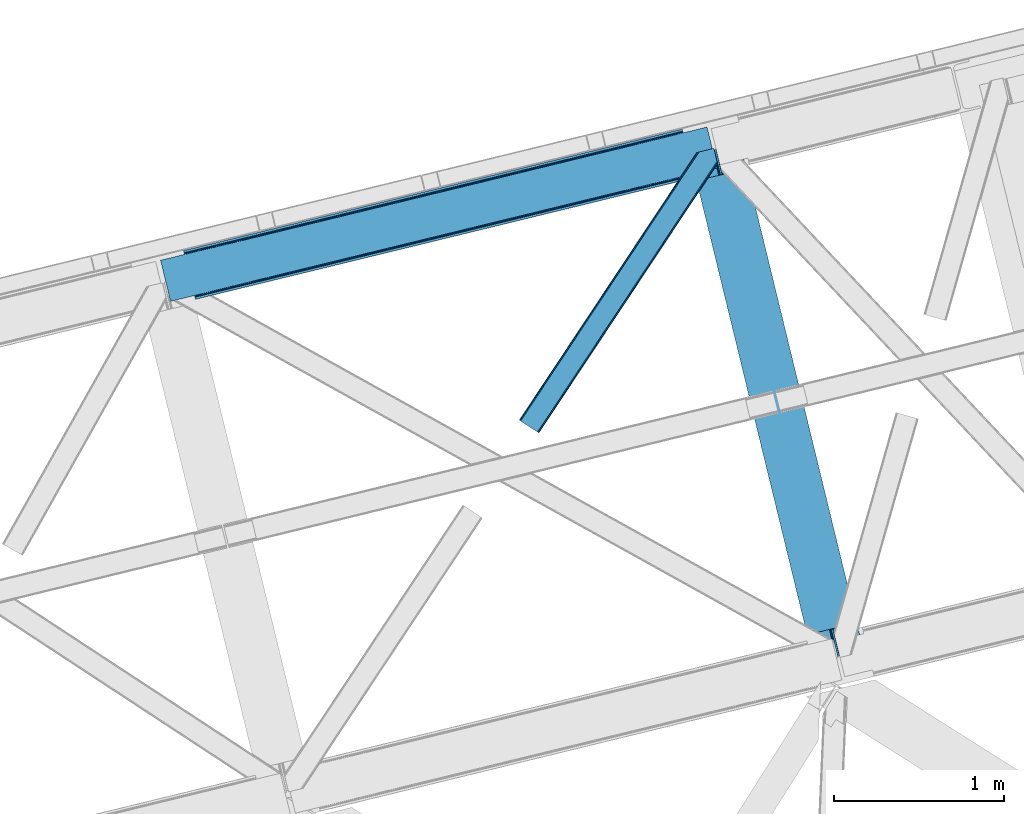
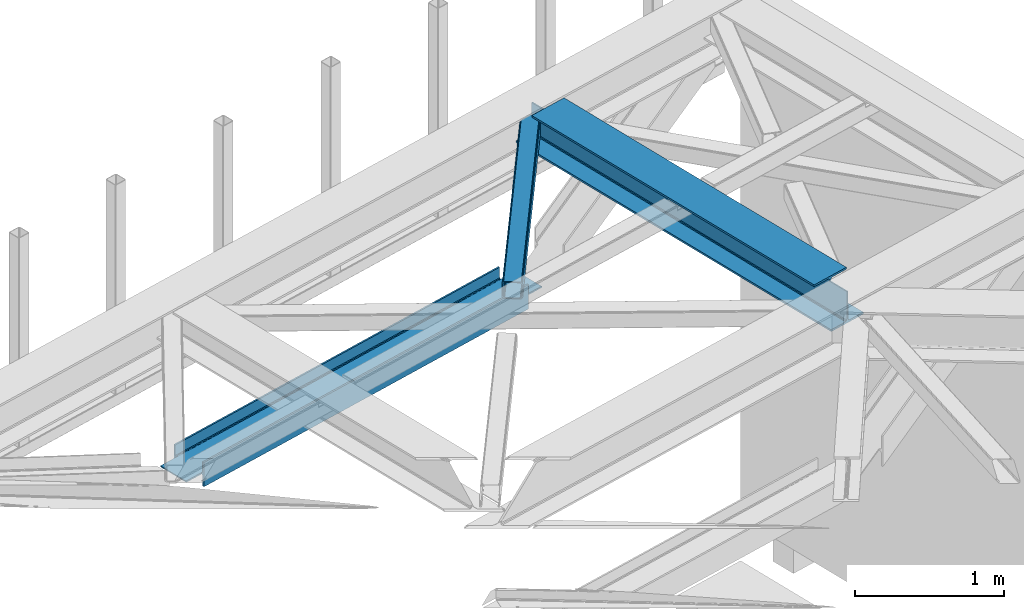
# One storey, part 60 of 67: 2 members, 1 beam.
"""IFC4 building model written with IfcOpenShell, lengths in millimetres."""

from ifc_helpers import new_model, entity, si_unit, converted_unit, derived_unit, direction, frame, origin, place, context, subcontext, project, spatial, triangles, polygons, material, type_object, element, save


model = new_model("IFC4")

# Units and contexts
model_context = context("Model", 3, precision=0.01, world=origin(), true_north=direction((6.12303176911189e-17, 1.0)))
plan_context = context("Plan", 3, precision=0.01, world=origin(), true_north=direction((6.12303176911189e-17, 1.0)))
body_context = subcontext(model_context, "Body", "Model", "MODEL_VIEW")
ifc_project = project(units=[si_unit("LENGTHUNIT", "METRE", prefix="MILLI"), si_unit("AREAUNIT", "SQUARE_METRE"), si_unit("VOLUMEUNIT", "CUBIC_METRE"), converted_unit("PLANEANGLEUNIT", "DEGREE", entity("IfcRatioMeasure", 0.0174532925199433), si_unit("PLANEANGLEUNIT", "RADIAN"), dimensions=[0, 0, 0, 0, 0, 0, 0]), si_unit("MASSUNIT", "GRAM", prefix="KILO"), derived_unit("MASSDENSITYUNIT", [(si_unit("MASSUNIT", "GRAM", prefix="KILO"), 1), (si_unit("LENGTHUNIT", "METRE"), -3)]), derived_unit("MOMENTOFINERTIAUNIT", [(si_unit("LENGTHUNIT", "METRE"), 4)]), si_unit("TIMEUNIT", "SECOND"), si_unit("FREQUENCYUNIT", "HERTZ"), si_unit("THERMODYNAMICTEMPERATUREUNIT", "DEGREE_CELSIUS"), derived_unit("THERMALTRANSMITTANCEUNIT", [(si_unit("MASSUNIT", "GRAM", prefix="KILO"), 1), (si_unit("THERMODYNAMICTEMPERATUREUNIT", "KELVIN"), -1), (si_unit("TIMEUNIT", "SECOND"), -3)]), derived_unit("VOLUMETRICFLOWRATEUNIT", [(si_unit("LENGTHUNIT", "METRE"), 3), (si_unit("TIMEUNIT", "SECOND"), -1)]), derived_unit("MASSFLOWRATEUNIT", [(si_unit("MASSUNIT", "GRAM", prefix="KILO"), 1), (si_unit("TIMEUNIT", "SECOND"), -1)]), derived_unit("ROTATIONALFREQUENCYUNIT", [(si_unit("TIMEUNIT", "SECOND"), -1)]), si_unit("ELECTRICCURRENTUNIT", "AMPERE"), si_unit("ELECTRICVOLTAGEUNIT", "VOLT"), si_unit("POWERUNIT", "WATT"), si_unit("FORCEUNIT", "NEWTON", prefix="KILO"), si_unit("ILLUMINANCEUNIT", "LUX"), si_unit("LUMINOUSFLUXUNIT", "LUMEN"), si_unit("LUMINOUSINTENSITYUNIT", "CANDELA"), derived_unit("USERDEFINED", [(si_unit("MASSUNIT", "GRAM", prefix="KILO"), -1), (si_unit("LENGTHUNIT", "METRE"), -2), (si_unit("TIMEUNIT", "SECOND"), 3), (si_unit("LUMINOUSFLUXUNIT", "LUMEN"), 1)]), derived_unit("LINEARVELOCITYUNIT", [(si_unit("LENGTHUNIT", "METRE"), 1), (si_unit("TIMEUNIT", "SECOND"), -1)]), si_unit("PRESSUREUNIT", "PASCAL"), derived_unit("USERDEFINED", [(si_unit("LENGTHUNIT", "METRE"), -2), (si_unit("MASSUNIT", "GRAM", prefix="KILO"), 1), (si_unit("TIMEUNIT", "SECOND"), -2)]), derived_unit("LINEARFORCEUNIT", [(si_unit("MASSUNIT", "GRAM", prefix="KILO"), 1), (si_unit("LENGTHUNIT", "METRE"), 1), (si_unit("TIMEUNIT", "SECOND"), -2), (si_unit("LENGTHUNIT", "METRE"), -1)]), derived_unit("PLANARFORCEUNIT", [(si_unit("MASSUNIT", "GRAM", prefix="KILO"), 1), (si_unit("LENGTHUNIT", "METRE"), 1), (si_unit("TIMEUNIT", "SECOND"), -2), (si_unit("LENGTHUNIT", "METRE"), -2)])], contexts=[model_context, plan_context])

# Site, building, storey
site_placement = place(None, origin())
site = spatial("IfcSite", under=ifc_project, at=site_placement, CompositionType="ELEMENT")
building_placement = place(site_placement, origin())
building = spatial("IfcBuilding", under=site, at=building_placement, CompositionType="ELEMENT")
storey_placement = place(building_placement, frame((0.0, 0.0, 19800.0)))
storey = spatial("IfcBuildingStorey", under=building, at=storey_placement, CompositionType="ELEMENT", Elevation=19800.0)

# Beam
ifc_material = material(Name="Metal painted (White)")
beam_type = type_object("IfcBeamType", PredefinedType="BEAM")
beam_placement = place(storey_placement, frame((-3043.27889836329, 17053.0977839193, 3807.02022389142)))
element("IfcBeam", 1, at=beam_placement, inside=storey, type_object=beam_type, material=ifc_material, ObjectType="Steel Beam", PredefinedType="BEAM", context=body_context, shape_type="Tessellation", body=[
    polygons([(1018.16648378329, 71.0478278971, 15.5000000000008), (1018.16648378329, 71.0478278971, 0.0), (291.465617442441, 3052.25531830421, 0.0), (291.46561744244, 3052.25531830421, 15.5000000000008), (894.779372399327, 40.970914087327, 15.5000000000008), (168.078506058477, 3022.17840449444, 15.5000000000008), (888.087028625373, 39.3395844888221, 16.8701684147984), (161.386162284522, 3020.54707489593, 16.8701684147984), (882.413533524753, 37.9566100336519, 20.7720779386391), (155.712667183902, 3019.16410044076, 20.7720779386391), (878.622625296174, 37.032536045914, 26.6116982174294), (151.921758955324, 3018.24002645303, 26.6116982174294), (877.29143535278, 36.7080444135029, 33.500000000001), (150.59056901193, 3017.91553482061, 33.500000000001), (140.875048430515, 3015.54727389071, 33.500000000001), (140.875048430516, 3015.54727389071, 259.000000000002), (150.590569011928, 3017.91553482061, 259.000000000002), (5.41433564649196e-13, 2981.20749040711, 0.0), (1.08286712929839e-12, 2981.20749040711, 15.4999999999965), (123.387111383957, 3011.28440421688, 15.5000000000008), (130.079455157929, 3012.91573381539, 16.8701684147984), (135.752950258545, 3014.29870827056, 20.7720779386391), (139.543858487118, 3015.22278225829, 26.6116982174294), (877.291435352778, 36.7080444135029, 259.000000000002), (867.575914771367, 34.3397834835992, 259.000000000002), (867.575914771365, 34.3397834835992, 33.500000000001), (866.244724827968, 34.0152918511816, 26.6116982174294), (862.453816599396, 33.0912178634502, 20.7720779386391), (856.78032149878, 31.70824340828, 16.8701684147984), (850.087977724808, 30.0769138097708, 15.5000000000008), (726.700866340852, -2.16573425859679e-12, 15.4999999999965), (726.700866340851, -2.16573425859679e-12, 0.0), (838.124523615906, 197.385937999179, 259.069791973884), (186.469722099963, 2870.72539801218, 259.000000000002), (186.693115201815, 2869.8089536072, 259.617303331124), (186.705504045442, 2869.75812937344, 266.500003008253), (837.97934480814, 197.9814160017, 266.500002998871), (837.979694928892, 197.979979696968, 260.000004007589), (828.499586345875, 194.645865944432, 259.006343171919), (828.276216326112, 195.562317481909, 259.617303331124), (828.263827482483, 195.613141715687, 266.500003008253), (176.989986719785, 2867.38985508742, 266.500002998871), (176.989636599033, 2867.39129139215, 260.000004007589), (176.844830940693, 2867.98534020594, 259.07612046749), (176.754201518551, 2868.35713708228, 259.000000000002), (839.310832678069, 198.30468544639, 273.388305639783), (843.101109266761, 199.231350618303, 279.227924098781), (848.7741802143, 200.616065081979, 283.129832400619), (855.466371895431, 202.248018612794, 284.500000377228), (978.853400583269, 232.325271667903, 284.500000138971), (978.851730776618, 232.332121736637, 299.999995328161), (687.386308679348, 161.283492472594, 299.999995890962), (687.387978485999, 161.276642403861, 284.500000701776), (810.775007173834, 191.35389545897, 284.500000463519), (817.467494069994, 192.984637925553, 283.129832461069), (823.141405718745, 194.365903570076, 279.227924137322), (826.932940505739, 195.28740721937, 273.388305663684), (175.658498849857, 2867.06658564273, 273.388305639783), (171.868222261161, 2866.13992047082, 279.227924098781), (166.195151313635, 2864.75520600714, 283.129832400619), (159.502959632485, 2863.12325247633, 284.500000377228), (36.115930944656, 2833.04599942122, 284.500000138971), (36.117600751305, 2833.03914935249, 299.999995328161), (327.583022848576, 2904.08777861653, 299.999995890962), (327.581353041926, 2904.09462868526, 284.500000701776), (204.194324354083, 2874.01737563015, 284.500000463519), (197.501837457941, 2872.38663316357, 283.129832461069), (191.827925809177, 2871.00536751904, 279.227924137322), (188.036391022187, 2870.08386386975, 273.388305663684)], [[[1, 2, 3, 4]], [[5, 1, 4, 6]], [[7, 5, 6, 8]], [[9, 7, 8, 10]], [[11, 9, 10, 12]], [[13, 11, 12, 14]], [[15, 16, 17, 14, 12, 10, 8, 6, 4, 3, 18, 19, 20, 21, 22, 23]], [[13, 24, 25, 26, 27, 28, 29, 30, 31, 32, 2, 1, 5, 7, 9, 11]], [[2, 32, 18, 3]], [[32, 31, 19, 18]], [[31, 30, 20, 19]], [[27, 26, 15, 23]], [[28, 27, 23, 22]], [[29, 28, 22, 21]], [[30, 29, 21, 20]], [[33, 24, 13, 14, 17, 34, 35, 36, 37, 38]], [[25, 39, 40, 41, 42, 43, 44, 16, 15, 26]], [[39, 25, 24, 33]], [[45, 34, 17, 16]], [[41, 40, 38, 37, 46, 47, 48, 49, 50, 51, 52, 53, 54, 55, 56, 57]], [[42, 58, 59, 60, 61, 62, 63, 64, 65, 66, 67, 68, 69, 36, 35, 43]], [[46, 37, 36, 69]], [[47, 46, 69, 68]], [[48, 47, 68, 67]], [[49, 48, 67, 66]], [[50, 49, 66, 65]], [[51, 50, 65, 64]], [[52, 51, 64, 63]], [[53, 52, 63, 62]], [[54, 53, 62, 61]], [[55, 54, 61, 60]], [[56, 55, 60, 59]], [[57, 56, 59, 58]], [[41, 57, 58, 42]]], closed=False),
])

# Members
member_type_1 = type_object("IfcMemberType", PredefinedType="BRACE")
member_1_placement = place(storey_placement, frame((-4050.77483825684, 18401.5802764893, 3823.02086791992)))
element("IfcMember", 2, at=member_1_placement, inside=storey, type_object=member_type_1, ObjectType="Steel Horizontal Brace", PredefinedType="BRACE", context=body_context, shape_type="Tessellation", body=[
    triangles([(1012.13822021484, 1571.4587310791, 0.0), (1045.99690933228, 1432.55790710449, 0.0), (14.5796333312987, 67.7191223144546, 0.0), (102.080397033692, 9.67499084472729, 0.0), (1.10807189941397, 76.6569488525383, 10.8016662597656), (0.0, 77.3929504394546, 17.4989318847656), (1043.79529953003, 1650.83760681152, 17.4989318847656), (1007.73296585083, 1592.73185119629, 9.25757446288844), (4.27125091552716, 74.5605651855476, 5.12526855468604), (1007.87191085815, 1593.1829864502, 9.49942016601563), (1007.5829750061, 1592.24815979004, 8.99945068359375), (1007.43734436035, 1591.76446838379, 8.74132690429542), (1007.29839935303, 1591.31333312989, 8.49948120117188), (1008.14776611328, 1587.8298248291, 5.12526855468604), (1046.0907989502, 1651.39571228027, 10.8691040039048), (1046.56518859863, 1651.51198425293, 9.49942016601563), (1009.97875900269, 1580.31865539551, 1.33247680663771), (9.00003204345694, 71.4212219238289, 1.33247680663771), (1043.79529953003, 1650.83760681152, 122.499499511716), (0.0, 77.3929504394546, 122.499499511716), (1045.70215988159, 1651.30269470215, 129.196765136716), (1.10807189941397, 76.6569488525383, 129.196765136716), (1051.1335144043, 1652.62586975098, 134.873162841795), (4.27125091552716, 74.5605651855476, 134.873162841795), (1059.25772781372, 1654.60481872559, 138.668280029295), (9.00003204345694, 71.4212219238289, 138.668280029295), (1068.84609603882, 1656.94421081543, 139.998431396481), (14.5796333312987, 67.7191223144546, 139.998431396481), (1012.24141159058, 1575.25849914551, 9.49942016601563), (1011.99578704834, 1574.65621032715, 9.42268066406177), (1012.03008728027, 1573.63069152832, 9.11572265625), (1012.0707824707, 1572.60052185059, 8.80643920898365), (1012.10973358154, 1571.57732849121, 8.49948120117188), (1065.96342315674, 1656.23960266114, 9.49942016601563), (14.8357223510743, 67.5516906738303, 8.33204956054396), (20.4150329589843, 63.8495910644524, 6.99957275390625), (1014.39534988403, 1562.19883117676, 6.99957275390625), (10.1022903442381, 70.6898712158218, 12.1248413085923), (1061.15121688843, 1655.06758117676, 12.1248413085923), (1012.24228363037, 1571.03317565918, 8.41343994140334), (1055.7242225647, 1653.74440612793, 17.8035644531228), (1053.81300201416, 1653.27931823731, 24.4985046386719), (6.94376220703134, 72.7874176025398, 17.8035644531228), (5.83074874877912, 73.5234191894524, 24.4985046386719), (1043.73948898315, 1441.81780700684, 6.99957275390625), (96.244997406006, 13.5445220947258, 6.99957275390625), (1045.89284591675, 1432.98578796387, 8.41343994140334), (1046.02539596558, 1432.44163513184, 8.49948120117188), (1050.83643951416, 1412.70330505371, 8.49948120117188), (1049.98707275391, 1416.18913879395, 5.12526855468604), (1048.15637054443, 1423.69798278809, 1.33247680663771), (1053.81300201416, 1653.27931823731, 115.49992675781), (5.83074874877912, 73.5234191894524, 115.49992675781), (1069.28008117676, 1657.04885559082, 131.666381835938), (1078.86844940186, 1659.38592224121, 132.998858642575), (20.4150329589843, 63.8495910644524, 132.998858642575), (14.8357223510743, 67.5516906738303, 131.666381835938), (1061.15121688843, 1655.06758117676, 127.873590087889), (10.1022903442381, 70.6898712158218, 127.873590087889), (1055.7242225647, 1653.74440612793, 122.19719238281), (6.94376220703134, 72.7874176025398, 122.19719238281), (1145.26875686646, 1675.57098083496, 139.998431396481), (1145.26875686646, 1675.57098083496, 132.998858642575), (1161.91250839233, 1607.29375305176, 139.998431396481), (102.080397033692, 9.67499084472729, 139.998431396481), (1159.65537872314, 1616.5536529541, 132.998858642575), (96.244997406006, 13.5445220947258, 132.998858642575), (1164.07226028442, 1598.43382873535, 138.668280029295), (107.659998321533, 5.97289123535302, 138.668280029295), (1165.9029624939, 1590.92265930176, 134.873162841795), (112.388779449463, 2.83354797363427, 134.873162841795), (1167.12614364624, 1585.90436096191, 129.196765136716), (115.551958465576, 0.737164306639897, 129.196765136716), (1167.55576858521, 1584.14167785645, 122.499499511716), (116.660321044922, 0.0, 122.499499511716), (1167.55576858521, 1584.14167785645, 17.4989318847656), (116.660321044922, 0.0, 17.4989318847656), (106.557740020752, 6.7042419433601, 127.873590087889), (109.716268157959, 4.60553283691479, 122.19719238281), (110.829281616211, 3.87069396972583, 115.49992675781), (101.824308013916, 9.84125976562427, 131.666381835938), (115.551958465576, 0.737164306639897, 10.8016662597656), (106.557740020752, 6.7042419433601, 12.1248413085923), (112.388779449463, 2.83354797363427, 5.12526855468604), (110.829281616211, 3.87069396972583, 24.4985046386719), (109.716268157959, 4.60553283691479, 17.8035644531228), (107.659998321533, 5.97289123535302, 1.33247680663771), (101.824308013916, 9.84125976562427, 8.33204956054396), (1165.29834823608, 1593.40157775879, 115.49992675781), (1165.29834823608, 1593.40157775879, 24.4985046386719), (1164.86901397705, 1595.16426086426, 122.19719238281), (1163.64554214478, 1600.1825592041, 127.873590087889), (1161.8148399353, 1607.6937286377, 131.666381835938), (1164.7812286377, 1595.52470397949, 17.868676757811), (1167.54646682739, 1584.18121032715, 16.4989929199219), (1164.67425842285, 1595.96188659668, 16.4989929199219), (1050.96404800415, 1412.49401550293, 8.8831787109375), (1051.5055847168, 1412.90561828614, 9.29943237304542), (1051.768359375, 1413.10328063965, 9.49942016601563), (1162.81652297974, 1579.82333679199, 10.8714294433594), (1161.66310501099, 1578.76061096192, 9.49942016601563), (1160.35097579956, 1595.22007141114, 12.1248413085923), (1046.70355224609, 1430.89521789551, 9.20641479492042), (1046.36229400635, 1431.66726379394, 8.85294799804615), (1047.39885864258, 1431.02776794434, 9.49942016601563), (1157.29360427856, 1596.68742370605, 9.49942016601563)], [[1, 2, 3], [4, 3, 2], [5, 6, 7], [8, 9, 10], [9, 8, 11], [12, 9, 11], [9, 12, 13], [13, 14, 9], [5, 15, 10], [10, 9, 5], [15, 16, 10], [17, 1, 18], [3, 18, 1], [14, 17, 9], [18, 9, 17], [7, 15, 5], [19, 7, 6], [6, 20, 19], [21, 19, 22], [20, 22, 19], [23, 21, 24], [22, 24, 21], [25, 23, 26], [24, 26, 23], [27, 25, 28], [26, 28, 25], [8, 10, 29], [11, 8, 30], [12, 11, 31], [13, 12, 32], [32, 33, 13], [31, 32, 12], [30, 31, 11], [29, 30, 8], [16, 34, 29], [29, 10, 16], [35, 36, 37], [38, 30, 29], [29, 39, 38], [29, 34, 39], [38, 35, 40], [40, 33, 38], [31, 38, 32], [31, 30, 38], [38, 33, 32], [37, 40, 35], [41, 42, 43], [44, 43, 42], [39, 41, 38], [43, 38, 41], [45, 37, 36], [36, 46, 45], [1, 37, 45], [13, 33, 14], [33, 40, 1], [37, 1, 40], [33, 17, 14], [33, 1, 17], [2, 1, 45], [2, 45, 47], [48, 2, 47], [49, 50, 48], [48, 51, 2], [48, 50, 51], [42, 52, 44], [53, 44, 52], [54, 55, 56], [56, 57, 54], [58, 54, 57], [57, 59, 58], [60, 58, 59], [59, 61, 60], [52, 60, 61], [61, 53, 52], [60, 19, 21], [54, 25, 27], [62, 55, 27], [55, 62, 63], [55, 54, 27], [58, 25, 54], [58, 60, 23], [23, 25, 58], [21, 23, 60], [42, 7, 19], [39, 16, 41], [60, 52, 19], [39, 34, 16], [42, 41, 7], [52, 42, 19], [15, 7, 41], [41, 16, 15], [64, 27, 65], [27, 64, 62], [28, 65, 27], [55, 66, 67], [55, 63, 66], [67, 56, 55], [68, 64, 65], [65, 69, 68], [70, 68, 69], [69, 71, 70], [72, 70, 71], [71, 73, 72], [74, 72, 73], [73, 75, 74], [76, 74, 77], [75, 77, 74], [73, 78, 79], [80, 77, 75], [73, 79, 75], [73, 71, 78], [79, 80, 75], [78, 71, 69], [67, 65, 28], [65, 81, 69], [81, 65, 67], [81, 78, 69], [82, 83, 84], [85, 77, 80], [77, 86, 82], [86, 77, 85], [82, 86, 83], [4, 46, 3], [87, 84, 83], [83, 88, 87], [88, 46, 4], [4, 87, 88], [59, 26, 24], [28, 56, 67], [28, 57, 56], [57, 28, 26], [59, 57, 26], [53, 20, 6], [22, 61, 59], [24, 22, 59], [61, 22, 20], [53, 61, 20], [18, 38, 9], [3, 46, 36], [36, 35, 3], [35, 38, 18], [18, 3, 35], [5, 9, 38], [6, 44, 53], [43, 6, 5], [6, 43, 44], [43, 5, 38], [89, 90, 85], [85, 80, 89], [91, 89, 79], [80, 79, 89], [92, 91, 78], [79, 78, 91], [93, 92, 81], [78, 81, 92], [66, 93, 67], [81, 67, 93], [94, 95, 96], [74, 76, 90], [76, 94, 90], [90, 89, 74], [76, 95, 94], [91, 74, 89], [72, 74, 91], [70, 91, 92], [91, 70, 72], [92, 68, 70], [93, 68, 92], [93, 66, 64], [93, 64, 68], [66, 62, 64], [66, 63, 62], [82, 97, 98], [99, 100, 82], [99, 101, 100], [84, 50, 97], [97, 82, 84], [77, 82, 100], [100, 76, 77], [100, 95, 76], [51, 50, 87], [84, 87, 50], [2, 51, 4], [87, 4, 51], [86, 85, 90], [86, 96, 102], [86, 94, 96], [103, 104, 88], [48, 88, 104], [83, 102, 105], [105, 88, 83], [102, 106, 105], [46, 88, 48], [48, 45, 46], [102, 83, 86], [90, 94, 86], [97, 48, 104], [97, 104, 105], [106, 101, 105], [99, 105, 101], [102, 95, 100], [102, 96, 95], [102, 101, 106], [100, 101, 102]]),
])
member_type_2 = type_object("IfcMemberType", PredefinedType="BRACE")
member_2_placement = place(storey_placement, frame((-6161.17154250439, 19176.7261427592, 2512.0)))
element("IfcMember", 3, at=member_2_placement, inside=storey, type_object=member_type_2, ObjectType="Steel Vertical Brace", PredefinedType="BRACE", context=body_context, shape_type="Tessellation", body=[
    polygons([(202.213006515029, 24.6242629021849, 77.7499999999953), (597.31084349256, 120.933540718255, 77.7499999999953), (1133.2837289006, 251.582602017925, 77.7499999999953), (1669.25661430864, 382.231663317597, 77.7499999999953), (2205.22949971669, 512.88072461726, 77.7499999999953), (2741.20238512474, 643.529785916932, 77.7499999999953), (3136.30022210225, 739.839063732998, 77.7499999999953), (3136.30022210225, 739.839063732998, 0.0), (202.213006515025, 24.6242629021849, 0.0), (3139.37896131113, 727.208886977162, 0.0), (205.291745723899, 11.9940861463463, 0.0), (3139.37896131113, 727.208886977162, 199.999999999998), (205.291745723903, 11.9940861463485, 199.999999999998), (3136.30022210225, 739.839063732998, 122.249999999994), (3136.30022210225, 739.839063732998, 199.999999999998), (3135.97573046984, 741.170253676395, 84.6383017825712), (3135.0516564821, 744.96116190497, 90.4779220613573), (3133.93196117233, 749.554584314495, 93.8745154964792), (3133.93196117236, 749.554584314417, 106.125484503402), (3135.0516564821, 744.96116190497, 109.522077938641), (3135.97573046984, 741.170253676395, 115.361698217427), (202.213006515033, 24.6242629021892, 122.249999999994), (201.888514882618, 25.9554528455858, 115.361698217427), (200.964440894883, 29.7463610741609, 109.522077938641), (199.844745585119, 34.339783483636, 106.125484503441), (199.844745585126, 34.3397834836057, 93.8745154965962), (200.964440894884, 29.7463610741609, 90.4779220613573), (201.888514882619, 25.9554528455858, 84.6383017825712), (202.213006515033, 24.6242629021892, 199.999999999998), (2634.00780804313, 617.399973656999, 122.249999999994), (1990.84034555346, 460.621100097393, 122.249999999994), (1347.67288306381, 303.842226537792, 122.249999999994), (704.505420574163, 147.063352978191, 122.249999999994), (2738.57084504939, 654.325379189628, 94.3798315850377), (2736.93951545091, 661.017722963482, 95.7499999999999), (3272.91240085895, 791.66678426315, 95.7499999999999), (3274.54373045746, 784.9744404892, 94.3798315851979), (2202.59795964137, 523.676317889856, 94.3798315852023), (2200.96663004286, 530.36866166381, 95.7499999999999), (1666.62507423332, 393.027256590189, 94.3798315852023), (1664.99374463482, 399.719600364143, 95.7499999999999), (1130.65218882528, 262.378195290517, 94.3798315852023), (1129.02085922678, 269.070539064473, 95.7499999999999), (594.679303417239, 131.729133990851, 94.3798315852023), (593.047973818735, 138.421477764808, 95.7499999999999), (58.7064180091819, 1.08007269117741, 94.3798315852023), (57.075088410676, 7.77241646513144, 95.7499999999999), (2203.98093409654, 518.002822789236, 90.4779220613573), (2739.95381950459, 648.651884088908, 90.4779220613573), (1668.00804868849, 387.353761489569, 90.4779220613573), (1132.03516328045, 256.704700189899, 90.4779220613573), (596.062277872437, 126.055638890125, 90.4779220615175), (2204.90500808427, 514.211914560661, 84.6383017825712), (2740.87789349232, 644.860975860333, 84.6383017825712), (1668.93212267623, 383.562853260994, 84.6383017825712), (1132.95923726819, 252.913791961324, 84.6383017825712), (596.986351860145, 122.264730661656, 84.6383017825712), (58.9696971545985, 6.49720277579036e-12, 93.8745154965962), (3274.80700960288, 783.894367798018, 93.8745154965962), (1990.51585392106, 461.952290040794, 115.361698217427), (2633.68331641071, 618.731163600395, 115.361698217427), (1347.34839143141, 305.173416481191, 115.361698217427), (704.180928941749, 148.394542921588, 115.361698217427), (1989.59177993332, 465.743198269369, 109.522077938641), (2632.75924242298, 622.522071828931, 109.522077938576), (1346.42431744367, 308.964324709768, 109.522077938641), (703.256854954015, 152.185451150165, 109.522077938641), (1988.20880547815, 471.416693369989, 105.620168414796), (2631.3762679678, 628.19556692959, 105.620168414796), (1345.0413429885, 314.637819810386, 105.620168414796), (701.873880498833, 157.858946250817, 105.620168414861), (2629.7449383693, 634.887910703549, 104.249999999998), (3274.54373045746, 784.974440489196, 105.620168414796), (3272.91240085896, 791.66678426315, 104.249999999998), (1986.57747587964, 478.109037143939, 104.249999999998), (1343.41001338999, 321.33016358434, 104.249999999998), (700.242550900338, 164.551290024739, 104.249999999998), (57.0750884106738, 7.77241646513144, 104.249999999998), (58.7064180091873, 1.08007269117957, 105.6201684148), (3274.80700960287, 783.894367798018, 106.125484503402), (58.9696971545985, 0.0, 106.125484503397), (3217.73192119221, 1018.03841381011, 95.7499999999999), (3216.10059159371, 1024.73075758407, 94.3798315852023), (3215.83731244829, 1025.81083027525, 93.8745154965962), (3215.83731244829, 1025.81083027525, 106.125484503397), (3216.10059159371, 1024.73075758407, 105.620168414796), (3217.73192119221, 1018.03841381011, 104.250000000002), (1.89460874392469, 234.144046012093, 104.250000000002), (0.263279145419858, 240.836389786054, 105.620168414796), (1.08286712929839e-12, 241.916462477225, 106.125484503402), (1.08286712929839e-12, 241.916462477225, 93.8745154965962), (0.26327914542419, 240.836389786054, 94.3798315852023), (1.89460874392469, 234.144046012093, 95.7499999999999), (645.06207123359, 390.922919571701, 95.7499999999999), (1288.22953372324, 547.701793131302, 95.7499999999999), (1931.39699621289, 704.480666690907, 95.7499999999999), (2574.56445870255, 861.259540250508, 95.7499999999999), (2681.75903578416, 887.389352510442, 104.250000000002), (2145.78615037611, 756.740291210774, 104.250000000002), (1609.81326496807, 626.091229911107, 104.250000000002), (1073.84037956003, 495.442168611439, 104.250000000002), (537.867494151986, 364.793107311767, 104.250000000002), (1927.45861817149, 720.637413794056, 84.6383017825712), (1927.13412653906, 721.968603737453, 77.7499999999953), (2570.30158902872, 878.747477297058, 77.7499999999953), (2570.62608066114, 877.416287353657, 84.6383017825712), (1284.29115568184, 563.858540234455, 84.6383017825712), (1283.96666404941, 565.189730177852, 77.7499999999953), (641.123693192179, 407.07966667485, 84.6383017825712), (640.799201559763, 408.410856618251, 77.7499999999953), (1928.38269215922, 716.846505565486, 90.4779220613573), (2571.55015464886, 873.625379125126, 90.4779220614179), (1285.21522966957, 560.06763200588, 90.4779220613573), (642.047767179914, 403.288758446279, 90.4779220613573), (1929.76566661439, 711.173010464866, 94.3798315852023), (2572.93312910405, 867.951884024467, 94.3798315852023), (1286.59820412474, 554.39413690526, 94.3798315852023), (643.430741635095, 397.615263345616, 94.3798315851416), (3072.59400308785, 1001.18656737306, 77.7499999999953), (3072.91849472027, 999.855377429661, 84.6383017825712), (3073.84256870799, 996.064469201147, 90.4779220614439), (3074.96226401778, 991.471046791609, 93.8745154965442), (139.755353120759, 280.849668370334, 90.4779220614439), (138.831279133037, 284.640576598848, 84.6383017825712), (138.506787500627, 285.971766542245, 77.7499999999953), (140.875048430544, 276.25624596077, 93.8745154965052), (2680.12770618568, 894.081696284296, 105.620168414956), (2144.15482077761, 763.432634984733, 105.620168414796), (1608.18193536956, 632.783573685065, 105.620168414796), (1072.20904996152, 502.134512385398, 105.620168414796), (536.236164553481, 371.48545108573, 105.620168414796), (2142.77184632243, 769.106130085348, 109.522077938641), (2678.74473173049, 899.755191385025, 109.522077938641), (1606.79896091439, 638.457068785685, 109.522077938641), (1070.82607550635, 507.808007486013, 109.522077938641), (534.853190098284, 377.158946186454, 109.522077938476), (2141.8477723347, 772.897038313923, 115.361698217427), (2677.82065774275, 903.546099613591, 115.361698217427), (1605.87488692666, 642.247977014256, 115.361698217427), (1069.90200151862, 511.598915714588, 115.361698217427), (533.929116110575, 380.949854414921, 115.361698217427), (2141.52328070228, 774.22822825732, 122.249999999994), (2677.49616611034, 904.877289556988, 122.249999999994), (1605.55039529424, 643.579166957652, 122.249999999994), (1069.5775098862, 512.930105657985, 122.249999999994), (533.60462447816, 382.281044358317, 122.249999999994), (3073.84256870796, 996.064469201242, 109.522077938415), (3072.91849472027, 999.855377429661, 115.361698217427), (3072.59400308785, 1001.18656737306, 122.249999999994), (138.506787500631, 285.971766542245, 122.249999999994), (138.831279133042, 284.640576598848, 115.361698217427), (139.755353120737, 280.849668370433, 109.522077938415), (140.875048430552, 276.256245960737, 106.125484503536), (3074.9622640178, 991.471046791483, 106.125484503623), (3072.59400308785, 1001.18656737305, 0.0), (3069.51526387898, 1013.81674412889, 0.0), (3069.51526387898, 1013.81674412889, 199.999999999998), (3072.59400308785, 1001.18656737305, 199.999999999998), (138.506787500633, 285.971766542245, 199.999999999998), (135.428048291758, 298.601943298085, 199.999999999998), (135.428048291758, 298.601943298085, 0.0), (138.506787500633, 285.971766542245, 0.0)], [[[1, 2, 3, 4, 5, 6, 7, 8, 9]], [[9, 8, 10, 11]], [[11, 10, 12, 13]], [[14, 15, 12, 10, 8, 7, 16, 17, 18, 19, 20, 21]], [[22, 23, 24, 25, 26, 27, 28, 1, 9, 11, 13, 29]], [[13, 12, 15, 29]], [[29, 15, 14, 30, 31, 32, 33, 22]], [[34, 35, 36, 37]], [[38, 39, 35, 34]], [[40, 41, 39, 38]], [[42, 43, 41, 40]], [[44, 45, 43, 42]], [[46, 47, 45, 44]], [[48, 38, 34, 49]], [[50, 40, 38, 48]], [[51, 42, 40, 50]], [[52, 44, 42, 51]], [[53, 48, 49, 54]], [[55, 50, 48, 53]], [[56, 51, 50, 55]], [[57, 52, 51, 56]], [[5, 53, 54, 6]], [[4, 55, 53, 5]], [[3, 56, 55, 4]], [[2, 57, 56, 3]], [[17, 16, 54, 49]], [[16, 7, 6, 54]], [[1, 28, 57, 2]], [[28, 27, 52, 57]], [[44, 26, 58, 46]], [[52, 26, 44]], [[26, 52, 27]], [[18, 37, 59]], [[49, 18, 17]], [[34, 18, 49]], [[18, 34, 37]], [[60, 31, 30, 61]], [[62, 32, 31, 60]], [[63, 33, 32, 62]], [[64, 60, 61, 65]], [[66, 62, 60, 64]], [[67, 63, 62, 66]], [[68, 64, 65, 69]], [[70, 66, 64, 68]], [[71, 67, 66, 70]], [[72, 69, 73, 74]], [[75, 68, 69, 72]], [[76, 70, 68, 75]], [[77, 71, 70, 76]], [[78, 79, 71, 77]], [[14, 21, 61, 30]], [[21, 20, 65, 61]], [[69, 19, 80, 73]], [[24, 23, 63, 67]], [[23, 22, 33, 63]], [[25, 79, 81]], [[67, 25, 24]], [[71, 25, 67]], [[25, 71, 79]], [[65, 19, 69]], [[19, 65, 20]], [[19, 18, 59, 80]], [[25, 81, 58, 26]], [[74, 73, 80, 59, 37, 36, 82, 83, 84, 85, 86, 87]], [[47, 46, 58, 81, 79, 78, 88, 89, 90, 91, 92, 93]], [[47, 93, 94, 95, 96, 97, 82, 36, 35, 39, 41, 43, 45]], [[88, 78, 77, 76, 75, 72, 74, 87, 98, 99, 100, 101, 102]], [[103, 104, 105, 106]], [[107, 108, 104, 103]], [[109, 110, 108, 107]], [[111, 103, 106, 112]], [[113, 107, 103, 111]], [[114, 109, 107, 113]], [[115, 111, 112, 116]], [[117, 113, 111, 115]], [[118, 114, 113, 117]], [[97, 116, 83, 82]], [[96, 115, 116, 97]], [[95, 117, 115, 96]], [[94, 118, 117, 95]], [[93, 92, 118, 94]], [[119, 120, 106, 105]], [[120, 121, 112, 106]], [[116, 122, 84, 83]], [[123, 124, 109, 114]], [[124, 125, 110, 109]], [[126, 92, 91]], [[114, 126, 123]], [[118, 126, 114]], [[126, 118, 92]], [[112, 122, 116]], [[122, 112, 121]], [[127, 98, 87, 86]], [[128, 99, 98, 127]], [[129, 100, 99, 128]], [[130, 101, 100, 129]], [[131, 102, 101, 130]], [[89, 88, 102, 131]], [[132, 128, 127, 133]], [[134, 129, 128, 132]], [[135, 130, 129, 134]], [[136, 131, 130, 135]], [[137, 132, 133, 138]], [[139, 134, 132, 137]], [[140, 135, 134, 139]], [[141, 136, 135, 140]], [[142, 137, 138, 143]], [[144, 139, 137, 142]], [[145, 140, 139, 144]], [[146, 141, 140, 145]], [[147, 148, 138, 133]], [[148, 149, 143, 138]], [[150, 151, 141, 146]], [[151, 152, 136, 141]], [[131, 153, 90, 89]], [[136, 153, 131]], [[153, 136, 152]], [[154, 86, 85]], [[133, 154, 147]], [[127, 154, 133]], [[154, 127, 86]], [[85, 84, 122, 154]], [[90, 153, 126, 91]], [[154, 122, 121, 120, 119, 155, 156, 157, 158, 149, 148, 147]], [[153, 152, 151, 150, 159, 160, 161, 162, 125, 124, 123, 126]], [[162, 155, 119, 105, 104, 108, 110, 125]], [[161, 156, 155, 162]], [[150, 146, 145, 144, 142, 143, 149, 158, 159]], [[159, 158, 157, 160]], [[160, 157, 156, 161]]], closed=True),
])

save(model, "model.ifc")
